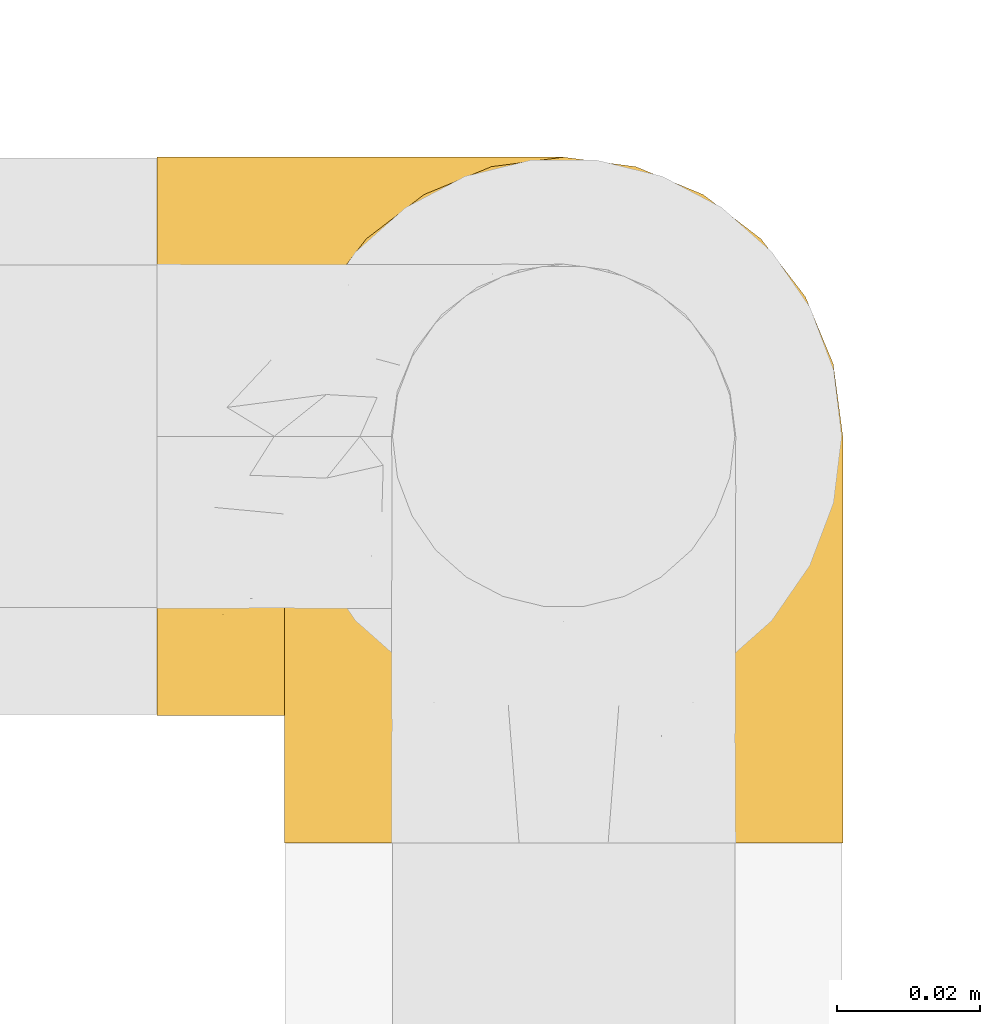
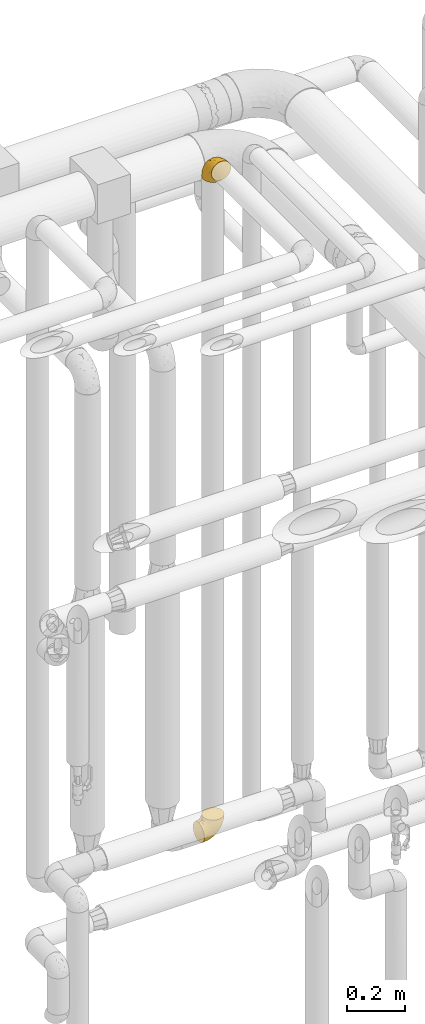
# One storey, part 501 of 827: 2 coverings.
"""IFC2X3 building model written with IfcOpenShell, lengths in millimetres."""

from ifc_helpers import new_model, entity, si_unit, converted_unit, derived_unit, direction, frame, origin, place, context, subcontext, project, spatial, faceted_brep, element, save


model = new_model("IFC2X3")

# Units and contexts
model_context = context("Model", 3, precision=0.01, world=origin(), true_north=direction((6.12303176911189e-17, 1.0)))
body_context = subcontext(model_context, "Body", "Model", "MODEL_VIEW")
ifc_project = project(units=[si_unit("LENGTHUNIT", "METRE", prefix="MILLI"), si_unit("AREAUNIT", "SQUARE_METRE"), si_unit("VOLUMEUNIT", "CUBIC_METRE"), converted_unit("PLANEANGLEUNIT", "DEGREE", entity("IfcRatioMeasure", 0.0174532925199433), si_unit("PLANEANGLEUNIT", "RADIAN"), dimensions=[0, 0, 0, 0, 0, 0, 0]), si_unit("MASSUNIT", "GRAM", prefix="KILO"), derived_unit("MASSDENSITYUNIT", [(si_unit("MASSUNIT", "GRAM", prefix="KILO"), 1), (si_unit("LENGTHUNIT", "METRE"), -3)]), derived_unit("MOMENTOFINERTIAUNIT", [(si_unit("LENGTHUNIT", "METRE"), 4)]), si_unit("TIMEUNIT", "SECOND"), si_unit("FREQUENCYUNIT", "HERTZ"), si_unit("THERMODYNAMICTEMPERATUREUNIT", "DEGREE_CELSIUS"), derived_unit("THERMALTRANSMITTANCEUNIT", [(si_unit("MASSUNIT", "GRAM", prefix="KILO"), 1), (si_unit("THERMODYNAMICTEMPERATUREUNIT", "KELVIN"), -1), (si_unit("TIMEUNIT", "SECOND"), -3)]), derived_unit("VOLUMETRICFLOWRATEUNIT", [(si_unit("LENGTHUNIT", "METRE"), 3), (si_unit("TIMEUNIT", "SECOND"), -1)]), derived_unit("MASSFLOWRATEUNIT", [(si_unit("MASSUNIT", "GRAM", prefix="KILO"), 1), (si_unit("TIMEUNIT", "SECOND"), -1)]), derived_unit("ROTATIONALFREQUENCYUNIT", [(si_unit("TIMEUNIT", "SECOND"), -1)]), si_unit("ELECTRICCURRENTUNIT", "AMPERE"), si_unit("ELECTRICVOLTAGEUNIT", "VOLT"), si_unit("POWERUNIT", "WATT"), si_unit("FORCEUNIT", "NEWTON", prefix="KILO"), si_unit("ILLUMINANCEUNIT", "LUX"), si_unit("LUMINOUSFLUXUNIT", "LUMEN"), si_unit("LUMINOUSINTENSITYUNIT", "CANDELA"), derived_unit("USERDEFINED", [(si_unit("MASSUNIT", "GRAM", prefix="KILO"), -1), (si_unit("LENGTHUNIT", "METRE"), -2), (si_unit("TIMEUNIT", "SECOND"), 3), (si_unit("LUMINOUSFLUXUNIT", "LUMEN"), 1)]), derived_unit("LINEARVELOCITYUNIT", [(si_unit("LENGTHUNIT", "METRE"), 1), (si_unit("TIMEUNIT", "SECOND"), -1)]), si_unit("PRESSUREUNIT", "PASCAL"), derived_unit("USERDEFINED", [(si_unit("LENGTHUNIT", "METRE"), -2), (si_unit("MASSUNIT", "GRAM", prefix="KILO"), 1), (si_unit("TIMEUNIT", "SECOND"), -2)]), derived_unit("LINEARFORCEUNIT", [(si_unit("MASSUNIT", "GRAM", prefix="KILO"), 1), (si_unit("LENGTHUNIT", "METRE"), 1), (si_unit("TIMEUNIT", "SECOND"), -2), (si_unit("LENGTHUNIT", "METRE"), -1)]), derived_unit("PLANARFORCEUNIT", [(si_unit("MASSUNIT", "GRAM", prefix="KILO"), 1), (si_unit("LENGTHUNIT", "METRE"), 1), (si_unit("TIMEUNIT", "SECOND"), -2), (si_unit("LENGTHUNIT", "METRE"), -2)])], contexts=[model_context])

# Site, building, storey
site_placement = place(None, origin())
site = spatial("IfcSite", under=ifc_project, at=site_placement, CompositionType="ELEMENT")
building_placement = place(site_placement, origin())
building = spatial("IfcBuilding", under=site, at=building_placement, CompositionType="ELEMENT")
storey_placement = place(building_placement, frame((0.0, 0.0, 28200.0)))
storey = spatial("IfcBuildingStorey", under=building, at=storey_placement, Name="08", CompositionType="ELEMENT", Elevation=28200.0)

# Coverings
covering_1_placement = place(storey_placement, frame((59757.39, 17441.4, 3141.4)))
element("IfcCovering", 1, at=covering_1_placement, inside=storey, Name=":ADSK_", ObjectType=":ADSK_", PredefinedType="INSULATION", context=body_context, shape_type="Brep", body=[
    faceted_brep([(79.9, 1.6, 58.6), (78.91, 1.6, 67.31), (76.02, 1.6, 75.59), (71.35, 1.6, 83.01), (65.15, 1.6, 89.21), (57.73, 1.6, 93.87), (49.45, 1.6, 96.76), (40.75, 1.6, 97.75), (32.03, 1.6, 96.76), (23.75, 1.6, 93.87), (16.33, 1.6, 89.2), (10.13, 1.6, 83.0), (5.47, 1.6, 75.58), (2.58, 1.6, 67.3), (1.6, 1.6, 58.6), (1.96, 1.6, 55.4), (2.58, 1.6, 49.88), (4.03, 1.6, 45.74), (5.48, 1.6, 41.6), (10.14, 1.6, 34.18), (16.34, 1.6, 27.98), (23.76, 1.6, 23.32), (32.04, 1.6, 20.43), (40.75, 1.6, 19.45), (49.46, 1.6, 20.43), (57.74, 1.6, 23.33), (65.16, 1.6, 27.99), (71.36, 1.6, 34.19), (76.02, 1.6, 41.61), (78.91, 1.6, 49.89), (79.54, 1.6, 55.4), (13.06, 30.91, 1.6), (6.84, 39.02, 1.6), (2.93, 48.46, 1.6), (2.44, 52.18, 1.6), (2.02, 55.39, 1.6), (1.6, 58.6, 1.6), (2.93, 68.73, 1.6), (6.84, 78.17, 1.6), (13.06, 86.28, 1.6), (21.17, 92.5, 1.6), (30.61, 96.41, 1.6), (40.75, 97.75, 1.6), (50.88, 96.41, 1.6), (60.32, 92.5, 1.6), (68.43, 86.28, 1.6), (74.65, 78.17, 1.6), (78.56, 68.73, 1.6), (79.9, 58.6, 1.6), (79.05, 52.18, 1.6), (78.56, 48.46, 1.6), (74.65, 39.02, 1.6), (68.43, 30.91, 1.6), (60.32, 24.69, 1.6), (50.88, 20.78, 1.6), (40.75, 19.45, 1.6), (30.61, 20.78, 1.6), (21.17, 24.69, 1.6), (40.75, 68.75, 68.75), (40.75, 58.11, 79.38), (53.99, 67.95, 67.95), (40.75, 79.38, 58.11), (40.75, 93.04, 31.31), (47.49, 94.13, 25.48), (40.75, 94.7, 20.85), (51.52, 83.92, 48.28), (61.86, 83.74, 38.29), (54.43, 92.46, 24.38), (63.37, 88.89, 18.7), (79.25, 18.55, 63.4), (77.04, 59.47, 43.9), (75.79, 73.43, 21.15), (72.61, 70.77, 41.26), (78.93, 64.34, 20.94), (70.12, 81.19, 24.69), (66.7, 24.77, 84.73), (72.7, 18.96, 79.29), (70.21, 39.69, 75.09), (78.8, 39.98, 55.53), (79.9, 23.41, 54.26), (79.9, 28.03, 51.17), (79.9, 32.65, 48.08), (79.9, 37.28, 44.99), (79.9, 41.9, 41.9), (74.44, 52.71, 59.1), (52.47, 24.51, 93.12), (79.33, 53.67, 38.11), (79.9, 44.99, 37.28), (79.9, 48.08, 32.65), (79.9, 51.17, 28.03), (79.9, 54.26, 23.41), (48.94, 45.31, 86.26), (58.78, 41.19, 84.36), (60.43, 18.54, 90.84), (40.75, 20.85, 94.7), (62.02, 67.52, 62.67), (57.53, 55.82, 76.37), (79.9, 5.17, 57.88), (79.9, 8.74, 57.17), (79.9, 15.88, 55.75), (64.12, 52.18, 74.1), (75.76, 35.23, 68.09), (76.65, 17.8, 72.38), (68.92, 60.91, 61.34), (66.73, 73.89, 48.69), (40.75, 86.21, 44.71), (40.75, 31.31, 93.04), (79.9, 55.75, 15.88), (79.9, 56.46, 12.31), (79.9, 57.17, 8.74), (40.75, 44.71, 86.21), (63.86, 26.29, 7.55), (69.15, 29.74, 12.14), (78.65, 47.68, 11.84), (72.98, 35.46, 9.55), (76.47, 41.52, 10.89), (76.82, 40.21, 17.57), (79.05, 47.09, 19.53), (79.09, 44.48, 25.5), (51.28, 19.96, 7.5), (51.03, 17.27, 12.73), (40.75, 14.22, 14.22), (40.75, 16.71, 8.19), (49.93, 10.14, 18.5), (58.53, 13.28, 20.38), (69.86, 17.56, 27.96), (65.19, 17.71, 22.53), (70.75, 23.15, 25.05), (79.25, 8.48, 51.05), (79.11, 13.45, 49.37), (57.89, 22.84, 6.49), (55.93, 7.02, 21.79), (78.06, 29.23, 37.29), (75.39, 29.51, 28.49), (78.16, 33.67, 33.82), (66.62, 23.34, 18.63), (73.14, 30.5, 21.37), (71.07, 7.97, 33.2), (78.32, 22.97, 42.33), (73.93, 16.17, 34.77), (77.25, 13.36, 42.81), (79.26, 19.39, 48.27), (60.3, 18.33, 17.49), (40.75, 8.19, 16.71), (65.72, 10.82, 26.81), (74.5, 23.48, 31.65), (60.62, 21.93, 12.9), (73.96, 34.48, 16.9), (77.3, 38.65, 23.37), (77.83, 36.64, 28.95), (23.6, 22.84, 6.49), (17.57, 25.49, 10.35), (1.6, 5.17, 57.88), (1.6, 8.74, 57.17), (1.6, 15.88, 55.75), (31.57, 10.14, 18.5), (22.97, 13.28, 20.37), (25.57, 7.02, 21.79), (15.78, 10.82, 26.8), (1.6, 55.75, 15.88), (1.6, 57.17, 8.74), (1.6, 57.88, 5.17), (12.34, 29.74, 12.14), (7.57, 34.5, 16.74), (8.85, 34.84, 10.0), (2.63, 46.53, 18.6), (4.67, 40.21, 17.57), (2.36, 44.84, 25.3), (1.6, 54.26, 23.41), (2.84, 47.68, 11.84), (2.24, 19.39, 48.27), (1.6, 28.03, 51.17), (3.18, 22.96, 42.31), (10.74, 23.16, 25.03), (15.18, 22.9, 18.73), (16.42, 17.91, 22.25), (30.21, 19.96, 7.5), (9.98, 28.63, 20.15), (30.46, 17.27, 12.73), (10.43, 7.97, 33.19), (12.05, 17.45, 27.5), (4.24, 13.36, 42.79), (7.56, 16.17, 34.75), (3.43, 29.23, 37.29), (2.38, 13.44, 49.36), (1.6, 23.41, 54.26), (3.66, 36.64, 28.95), (4.45, 38.11, 22.98), (6.98, 23.51, 31.63), (6.12, 29.52, 28.42), (5.38, 40.9, 10.01), (21.58, 18.21, 17.3), (3.35, 33.63, 33.78), (1.6, 37.28, 44.99), (20.87, 21.93, 12.9), (1.6, 44.99, 37.28), (1.6, 41.9, 41.9), (1.6, 51.17, 28.03), (1.6, 48.08, 32.65), (1.6, 32.65, 48.08), (2.16, 53.67, 38.11), (11.37, 81.19, 24.7), (5.7, 73.43, 21.15), (8.88, 70.76, 41.27), (12.57, 60.91, 61.33), (7.04, 52.7, 59.09), (11.27, 39.68, 75.08), (17.36, 52.18, 74.09), (2.69, 39.98, 55.53), (2.56, 64.34, 20.94), (34.0, 94.13, 25.48), (27.06, 92.46, 24.38), (4.45, 59.46, 43.89), (5.73, 35.22, 68.08), (18.12, 88.89, 18.7), (19.63, 83.74, 38.29), (27.49, 67.95, 67.95), (19.46, 67.52, 62.66), (2.24, 18.55, 63.4), (29.01, 24.51, 93.12), (14.78, 24.77, 84.73), (32.55, 45.32, 86.25), (8.78, 18.96, 79.28), (29.98, 83.92, 48.28), (23.95, 55.82, 76.37), (22.7, 41.19, 84.35), (21.05, 18.54, 90.83), (14.75, 73.87, 48.7), (4.84, 17.8, 72.37)], [[[0, 1, 2, 3, 4, 5, 6, 7, 8, 9, 10, 11, 12, 13, 14, 15, 16, 17, 18, 19, 20, 21, 22, 23, 24, 25, 26, 27, 28, 29, 30]], [[31, 32, 33, 34, 35, 36, 37, 38, 39, 40, 41, 42, 43, 44, 45, 46, 47, 48, 49, 50, 51, 52, 53, 54, 55, 56, 57]], [[58, 59, 60, 61]], [[62, 63, 64]], [[65, 66, 67]], [[67, 66, 68]], [[69, 1, 0]], [[70, 71, 72]], [[44, 43, 67]], [[47, 71, 73]], [[45, 74, 46]], [[68, 45, 44]], [[75, 76, 77]], [[76, 3, 2]], [[78, 79, 80, 81, 82, 83]], [[48, 47, 73]], [[70, 72, 84]], [[5, 85, 6]], [[86, 83, 87, 88, 89, 90]], [[91, 85, 92]], [[76, 75, 3]], [[71, 46, 74]], [[85, 5, 93]], [[45, 68, 74]], [[5, 4, 93]], [[85, 94, 6]], [[86, 78, 83]], [[60, 95, 65]], [[96, 95, 60]], [[75, 4, 3]], [[69, 0, 97, 98, 99, 79]], [[75, 77, 100]], [[43, 64, 63]], [[101, 102, 69]], [[101, 76, 102]], [[46, 71, 47]], [[95, 103, 104]], [[92, 85, 93]], [[63, 105, 65]], [[92, 75, 100]], [[91, 106, 85]], [[84, 78, 70]], [[67, 68, 44]], [[65, 67, 63]], [[65, 61, 60]], [[4, 75, 93]], [[92, 93, 75]], [[102, 76, 2]], [[77, 76, 101]], [[84, 77, 101]], [[77, 103, 100]], [[72, 71, 74]], [[70, 86, 73]], [[104, 74, 66]], [[84, 72, 103]], [[70, 73, 71]], [[73, 90, 107, 108, 109, 48]], [[79, 78, 69]], [[101, 69, 78]], [[91, 92, 96]], [[91, 59, 110, 106]], [[2, 1, 102]], [[69, 102, 1]], [[94, 85, 106]], [[94, 7, 6]], [[74, 68, 66]], [[43, 42, 64]], [[43, 63, 67]], [[73, 86, 90]], [[78, 86, 70]], [[95, 100, 103]], [[96, 92, 100]], [[104, 103, 72]], [[65, 95, 66]], [[74, 104, 72]], [[66, 95, 104]], [[95, 96, 100]], [[91, 96, 60]], [[77, 84, 103]], [[78, 84, 101]], [[60, 59, 91]], [[105, 63, 62]], [[105, 61, 65]], [[111, 52, 112]], [[107, 90, 113]], [[114, 115, 116]], [[50, 107, 113]], [[117, 118, 116]], [[54, 119, 55]], [[97, 0, 30, 29, 98]], [[113, 115, 51]], [[120, 121, 122]], [[123, 120, 124]], [[125, 126, 127]], [[128, 28, 129]], [[130, 54, 53]], [[25, 24, 131]], [[132, 133, 134]], [[135, 112, 136]], [[137, 27, 26]], [[121, 120, 123]], [[138, 139, 132]], [[129, 140, 141]], [[135, 126, 142]], [[27, 140, 28]], [[27, 137, 140]], [[49, 48, 109, 108, 107, 50]], [[23, 143, 121, 123]], [[25, 131, 144]], [[26, 25, 144]], [[128, 98, 29]], [[125, 127, 145]], [[146, 130, 111]], [[137, 144, 139]], [[139, 138, 140]], [[116, 147, 114]], [[123, 124, 131]], [[116, 118, 148]], [[134, 83, 82]], [[129, 79, 99]], [[54, 130, 119]], [[141, 79, 129]], [[122, 55, 119]], [[120, 146, 142]], [[117, 113, 90]], [[50, 113, 51]], [[127, 133, 145]], [[147, 136, 112]], [[136, 133, 127]], [[24, 23, 123]], [[118, 117, 89]], [[149, 87, 134]], [[144, 131, 124]], [[24, 123, 131]], [[128, 129, 99]], [[28, 140, 129]], [[144, 137, 26]], [[140, 137, 139]], [[81, 138, 132]], [[138, 80, 141]], [[89, 88, 87, 118]], [[115, 117, 116]], [[140, 138, 141]], [[148, 118, 149]], [[136, 148, 149]], [[147, 116, 148]], [[133, 136, 149]], [[127, 126, 135]], [[136, 147, 148]], [[114, 112, 52]], [[112, 114, 147]], [[51, 114, 52]], [[51, 115, 114]], [[117, 115, 113]], [[117, 90, 89]], [[134, 133, 149]], [[145, 133, 132]], [[132, 139, 145]], [[125, 139, 144]], [[139, 125, 145]], [[126, 144, 124]], [[144, 126, 125]], [[142, 126, 124]], [[120, 142, 124]], [[142, 146, 135]], [[112, 135, 146]], [[136, 127, 135]], [[118, 87, 149]], [[82, 81, 132]], [[111, 130, 53]], [[119, 146, 120]], [[146, 119, 130]], [[122, 119, 120]], [[52, 111, 53]], [[146, 111, 112]], [[134, 82, 132]], [[83, 134, 87]], [[98, 128, 99]], [[80, 138, 81]], [[80, 79, 141]], [[28, 128, 29]], [[150, 151, 57]], [[15, 14, 152, 153, 154, 16]], [[121, 143, 23, 155]], [[150, 57, 56]], [[156, 157, 158]], [[35, 34, 33, 159, 160, 161, 36]], [[162, 31, 57]], [[163, 164, 162]], [[165, 166, 167]], [[155, 23, 22]], [[168, 159, 169]], [[170, 171, 172]], [[173, 174, 175]], [[55, 122, 176]], [[177, 174, 173]], [[22, 157, 155]], [[178, 121, 155]], [[169, 33, 32]], [[20, 19, 179]], [[21, 20, 158]], [[158, 180, 175]], [[181, 182, 179]], [[172, 183, 182]], [[122, 121, 178]], [[181, 19, 18]], [[184, 185, 170]], [[17, 154, 184]], [[186, 187, 177]], [[187, 186, 167]], [[179, 158, 20]], [[21, 157, 22]], [[175, 180, 173]], [[188, 189, 173]], [[164, 166, 190]], [[185, 184, 154]], [[181, 172, 182]], [[156, 191, 178]], [[192, 183, 193]], [[178, 176, 122]], [[194, 150, 176]], [[33, 169, 159]], [[190, 169, 32]], [[189, 192, 186]], [[180, 188, 173]], [[167, 166, 187]], [[166, 164, 163]], [[195, 192, 196]], [[158, 157, 21]], [[155, 157, 156]], [[178, 155, 156]], [[181, 18, 184]], [[17, 16, 154]], [[181, 179, 19]], [[158, 179, 182]], [[170, 181, 184]], [[192, 195, 186]], [[31, 190, 32]], [[165, 190, 166]], [[190, 31, 164]], [[31, 162, 164]], [[177, 163, 162]], [[187, 166, 163]], [[151, 174, 177]], [[177, 173, 189]], [[177, 187, 163]], [[195, 167, 186]], [[165, 197, 168]], [[165, 168, 169]], [[167, 197, 165]], [[190, 165, 169]], [[167, 195, 198, 197]], [[151, 177, 162]], [[175, 191, 156]], [[191, 174, 194]], [[158, 175, 156]], [[174, 191, 175]], [[178, 191, 194]], [[158, 182, 180]], [[188, 182, 183]], [[182, 188, 180]], [[183, 192, 189]], [[183, 189, 188]], [[177, 189, 186]], [[183, 199, 193]], [[176, 150, 56]], [[151, 150, 194]], [[176, 56, 55]], [[194, 176, 178]], [[174, 151, 194]], [[57, 151, 162]], [[199, 183, 172]], [[196, 192, 193]], [[171, 199, 172]], [[172, 181, 170]], [[170, 185, 171]], [[184, 18, 17]], [[200, 168, 197, 198, 195, 196]], [[201, 202, 203]], [[204, 203, 205]], [[204, 206, 207]], [[208, 196, 193, 199, 171, 185]], [[209, 36, 161, 160, 159, 168]], [[202, 38, 37]], [[201, 38, 202]], [[210, 41, 211]], [[200, 208, 212]], [[205, 208, 213]], [[214, 211, 40]], [[40, 211, 41]], [[214, 201, 215]], [[58, 61, 216, 59]], [[201, 39, 38]], [[207, 217, 204]], [[213, 208, 218]], [[218, 185, 154, 153, 152, 14]], [[14, 13, 218]], [[9, 8, 219]], [[10, 220, 11]], [[221, 106, 110, 59]], [[219, 8, 94]], [[220, 222, 11]], [[223, 211, 215]], [[221, 216, 224]], [[225, 219, 221]], [[10, 9, 226]], [[213, 222, 206]], [[226, 9, 219]], [[106, 219, 94]], [[212, 202, 209]], [[201, 203, 227]], [[226, 225, 220]], [[207, 206, 220]], [[214, 40, 39]], [[11, 222, 12]], [[12, 222, 228]], [[41, 210, 64]], [[223, 105, 210]], [[223, 215, 217]], [[105, 62, 210]], [[206, 222, 220]], [[228, 222, 213]], [[207, 220, 225]], [[205, 206, 204]], [[225, 226, 219]], [[220, 10, 226]], [[209, 202, 37]], [[203, 202, 212]], [[205, 203, 212]], [[204, 217, 227]], [[36, 209, 37]], [[209, 168, 200]], [[218, 13, 228]], [[208, 185, 218]], [[106, 221, 219]], [[221, 59, 216]], [[218, 228, 213]], [[13, 12, 228]], [[8, 7, 94]], [[201, 214, 39]], [[211, 214, 215]], [[64, 210, 62]], [[64, 42, 41]], [[223, 210, 211]], [[208, 200, 196]], [[209, 200, 212]], [[225, 224, 207]], [[207, 224, 217]], [[223, 217, 216]], [[204, 227, 203]], [[217, 215, 227]], [[201, 227, 215]], [[221, 224, 225]], [[217, 224, 216]], [[208, 205, 212]], [[206, 205, 213]], [[216, 61, 223]], [[223, 61, 105]]]),
])
covering_2_placement = place(storey_placement, frame((59739.54, 17459.25, 359.25)))
element("IfcCovering", 2, at=covering_2_placement, inside=storey, Name=":ADSK_", ObjectType=":ADSK_", PredefinedType="INSULATION", context=body_context, shape_type="Brep", body=[
    faceted_brep([(1.6, 79.9, 40.75), (1.6, 78.91, 32.03), (1.6, 76.02, 23.75), (1.6, 71.35, 16.33), (1.6, 65.15, 10.13), (1.6, 57.73, 5.47), (1.6, 49.45, 2.58), (1.6, 40.75, 1.6), (1.6, 32.03, 2.58), (1.6, 23.75, 5.48), (1.6, 16.33, 10.14), (1.6, 10.13, 16.34), (1.6, 5.47, 23.76), (1.6, 2.58, 32.04), (1.6, 1.6, 40.75), (1.6, 1.96, 43.94), (1.6, 2.58, 49.46), (1.6, 4.03, 53.6), (1.6, 5.48, 57.74), (1.6, 10.14, 65.16), (1.6, 16.34, 71.36), (1.6, 23.76, 76.02), (1.6, 32.04, 78.91), (1.6, 40.75, 79.9), (1.6, 49.46, 78.91), (1.6, 57.74, 76.02), (1.6, 65.16, 71.35), (1.6, 71.36, 65.15), (1.6, 76.02, 57.73), (1.6, 78.91, 49.45), (1.6, 79.54, 43.94), (30.91, 13.06, 97.75), (39.02, 6.84, 97.75), (48.46, 2.93, 97.75), (52.18, 2.44, 97.75), (55.39, 2.02, 97.75), (58.6, 1.6, 97.75), (68.73, 2.93, 97.75), (78.17, 6.84, 97.75), (86.28, 13.06, 97.75), (92.5, 21.17, 97.75), (96.41, 30.61, 97.75), (97.75, 40.75, 97.75), (96.41, 50.88, 97.75), (92.5, 60.32, 97.75), (86.28, 68.43, 97.75), (78.17, 74.65, 97.75), (68.73, 78.56, 97.75), (58.6, 79.9, 97.75), (52.18, 79.05, 97.75), (48.46, 78.56, 97.75), (39.02, 74.65, 97.75), (30.91, 68.43, 97.75), (24.69, 60.32, 97.75), (20.78, 50.88, 97.75), (19.45, 40.75, 97.75), (20.78, 30.61, 97.75), (24.69, 21.17, 97.75), (68.75, 40.75, 30.59), (58.11, 40.75, 19.96), (67.95, 53.99, 31.39), (79.38, 40.75, 41.23), (93.04, 40.75, 68.03), (94.13, 47.49, 73.86), (94.7, 40.75, 78.49), (83.92, 51.52, 51.06), (83.74, 61.86, 61.05), (92.46, 54.43, 74.96), (88.89, 63.37, 80.64), (18.55, 79.25, 35.94), (59.47, 77.04, 55.44), (73.43, 75.79, 78.19), (70.77, 72.61, 58.08), (64.34, 78.93, 78.4), (81.19, 70.12, 74.65), (24.77, 66.7, 14.61), (18.96, 72.7, 20.05), (39.69, 70.21, 24.25), (39.98, 78.8, 43.81), (23.41, 79.9, 45.08), (28.03, 79.9, 48.17), (32.65, 79.9, 51.26), (37.28, 79.9, 54.35), (41.9, 79.9, 57.44), (52.71, 74.44, 40.25), (24.51, 52.47, 6.22), (53.67, 79.33, 61.23), (44.99, 79.9, 62.06), (48.08, 79.9, 66.69), (51.17, 79.9, 71.31), (54.26, 79.9, 75.93), (45.31, 48.94, 13.08), (41.19, 58.78, 14.98), (18.54, 60.43, 8.5), (20.85, 40.75, 4.64), (67.52, 62.02, 36.67), (55.82, 57.53, 22.97), (5.17, 79.9, 41.46), (8.74, 79.9, 42.17), (15.88, 79.9, 43.59), (52.18, 64.12, 25.24), (35.23, 75.76, 31.25), (17.8, 76.65, 26.96), (60.91, 68.92, 38.0), (73.89, 66.73, 50.65), (86.21, 40.75, 54.63), (31.31, 40.75, 6.3), (55.75, 79.9, 83.46), (56.46, 79.9, 87.03), (57.17, 79.9, 90.6), (44.71, 40.75, 13.13), (26.29, 63.86, 91.79), (29.74, 69.15, 87.2), (47.68, 78.65, 87.5), (35.46, 72.98, 89.79), (41.52, 76.47, 88.45), (40.21, 76.82, 81.77), (47.09, 79.05, 79.81), (44.48, 79.09, 73.84), (19.96, 51.28, 91.84), (17.27, 51.03, 86.62), (14.22, 40.75, 85.12), (16.71, 40.75, 91.15), (10.14, 49.93, 80.84), (13.28, 58.53, 78.96), (17.56, 69.86, 71.38), (17.71, 65.19, 76.81), (23.15, 70.75, 74.29), (8.48, 79.25, 48.29), (13.45, 79.11, 49.97), (22.84, 57.89, 92.85), (7.02, 55.93, 77.55), (29.23, 78.06, 62.05), (29.51, 75.39, 70.85), (33.67, 78.16, 65.52), (23.34, 66.62, 80.71), (30.5, 73.14, 77.97), (7.97, 71.07, 66.14), (22.97, 78.32, 57.01), (16.17, 73.93, 64.57), (13.36, 77.25, 56.53), (19.39, 79.26, 51.07), (18.33, 60.3, 81.85), (8.19, 40.75, 82.63), (10.82, 65.72, 72.53), (23.48, 74.5, 67.69), (21.93, 60.62, 86.44), (34.48, 73.96, 82.44), (38.65, 77.3, 75.97), (36.64, 77.83, 70.39), (22.84, 23.6, 92.85), (25.49, 17.57, 88.99), (5.17, 1.6, 41.46), (8.74, 1.6, 42.17), (15.88, 1.6, 43.59), (10.14, 31.57, 80.84), (13.28, 22.97, 78.97), (7.02, 25.57, 77.55), (10.82, 15.78, 72.54), (55.75, 1.6, 83.46), (57.17, 1.6, 90.6), (57.88, 1.6, 94.17), (29.74, 12.34, 87.2), (34.5, 7.57, 82.6), (34.84, 8.85, 89.34), (46.53, 2.63, 80.74), (40.21, 4.67, 81.77), (44.84, 2.36, 74.04), (54.26, 1.6, 75.93), (47.68, 2.84, 87.5), (19.39, 2.24, 51.07), (28.03, 1.6, 48.17), (22.96, 3.18, 57.03), (23.16, 10.74, 74.31), (22.9, 15.18, 80.61), (17.91, 16.42, 77.09), (19.96, 30.21, 91.84), (28.63, 9.98, 79.19), (17.27, 30.46, 86.62), (7.97, 10.43, 66.15), (17.45, 12.05, 71.84), (13.36, 4.24, 56.55), (16.17, 7.56, 64.59), (29.23, 3.43, 62.05), (13.44, 2.38, 49.99), (23.41, 1.6, 45.08), (36.64, 3.66, 70.39), (38.11, 4.45, 76.36), (23.51, 6.98, 67.71), (29.52, 6.12, 70.92), (40.9, 5.38, 89.33), (18.21, 21.58, 82.04), (32.65, 1.6, 51.26), (21.93, 20.87, 86.44), (33.63, 3.35, 65.56), (44.99, 1.6, 62.06), (41.9, 1.6, 57.44), (37.28, 1.6, 54.35), (51.17, 1.6, 71.31), (48.08, 1.6, 66.69), (53.67, 2.16, 61.23), (81.19, 11.37, 74.65), (73.43, 5.7, 78.19), (70.76, 8.88, 58.07), (60.91, 12.57, 38.01), (52.7, 7.04, 40.25), (39.68, 11.27, 24.26), (52.18, 17.36, 25.25), (39.98, 2.69, 43.81), (64.34, 2.56, 78.4), (94.13, 34.0, 73.86), (92.46, 27.06, 74.96), (59.46, 4.45, 55.45), (35.22, 5.73, 31.26), (88.89, 18.12, 80.64), (83.74, 19.63, 61.05), (67.95, 27.49, 31.39), (67.52, 19.46, 36.69), (18.55, 2.24, 35.95), (24.51, 29.01, 6.22), (24.77, 14.78, 14.62), (45.32, 32.55, 13.09), (18.96, 8.78, 20.06), (83.92, 29.98, 51.06), (55.82, 23.95, 22.97), (41.19, 22.7, 14.99), (18.54, 21.05, 8.51), (73.87, 14.75, 50.64), (17.8, 4.84, 26.97)], [[[0, 1, 2, 3, 4, 5, 6, 7, 8, 9, 10, 11, 12, 13, 14, 15, 16, 17, 18, 19, 20, 21, 22, 23, 24, 25, 26, 27, 28, 29, 30]], [[31, 32, 33, 34, 35, 36, 37, 38, 39, 40, 41, 42, 43, 44, 45, 46, 47, 48, 49, 50, 51, 52, 53, 54, 55, 56, 57]], [[58, 59, 60, 61]], [[62, 63, 64]], [[65, 66, 67]], [[67, 66, 68]], [[69, 1, 0]], [[70, 71, 72]], [[44, 43, 67]], [[47, 71, 73]], [[45, 74, 46]], [[68, 45, 44]], [[75, 76, 77]], [[76, 3, 2]], [[78, 79, 80, 81, 82, 83]], [[48, 47, 73]], [[70, 72, 84]], [[5, 85, 6]], [[86, 83, 87, 88, 89, 90]], [[91, 85, 92]], [[76, 75, 3]], [[71, 46, 74]], [[85, 5, 93]], [[45, 68, 74]], [[5, 4, 93]], [[85, 94, 6]], [[86, 78, 83]], [[60, 95, 65]], [[96, 95, 60]], [[75, 4, 3]], [[69, 0, 97, 98, 99, 79]], [[75, 77, 100]], [[43, 64, 63]], [[101, 102, 69]], [[101, 76, 102]], [[46, 71, 47]], [[95, 103, 104]], [[92, 85, 93]], [[63, 105, 65]], [[92, 75, 100]], [[91, 106, 85]], [[84, 78, 70]], [[67, 68, 44]], [[65, 67, 63]], [[65, 61, 60]], [[4, 75, 93]], [[92, 93, 75]], [[102, 76, 2]], [[77, 76, 101]], [[84, 77, 101]], [[77, 103, 100]], [[72, 71, 74]], [[70, 86, 73]], [[104, 74, 66]], [[84, 72, 103]], [[70, 73, 71]], [[73, 90, 107, 108, 109, 48]], [[79, 78, 69]], [[101, 69, 78]], [[91, 92, 96]], [[91, 59, 110, 106]], [[2, 1, 102]], [[69, 102, 1]], [[94, 85, 106]], [[94, 7, 6]], [[74, 68, 66]], [[43, 42, 64]], [[43, 63, 67]], [[73, 86, 90]], [[78, 86, 70]], [[95, 100, 103]], [[96, 92, 100]], [[104, 103, 72]], [[65, 95, 66]], [[74, 104, 72]], [[66, 95, 104]], [[95, 96, 100]], [[91, 96, 60]], [[77, 84, 103]], [[78, 84, 101]], [[60, 59, 91]], [[105, 63, 62]], [[105, 61, 65]], [[111, 52, 112]], [[107, 90, 113]], [[114, 115, 116]], [[50, 107, 113]], [[117, 118, 116]], [[54, 119, 55]], [[97, 0, 30, 29, 98]], [[113, 115, 51]], [[120, 121, 122]], [[123, 120, 124]], [[125, 126, 127]], [[128, 28, 129]], [[130, 54, 53]], [[25, 24, 131]], [[132, 133, 134]], [[135, 112, 136]], [[137, 27, 26]], [[121, 120, 123]], [[138, 139, 132]], [[129, 140, 141]], [[135, 126, 142]], [[27, 140, 28]], [[27, 137, 140]], [[49, 48, 109, 108, 107, 50]], [[23, 143, 121, 123]], [[25, 131, 144]], [[26, 25, 144]], [[128, 98, 29]], [[125, 127, 145]], [[146, 130, 111]], [[137, 144, 139]], [[139, 138, 140]], [[116, 147, 114]], [[123, 124, 131]], [[116, 118, 148]], [[134, 83, 82]], [[129, 79, 99]], [[54, 130, 119]], [[141, 79, 129]], [[122, 55, 119]], [[120, 146, 142]], [[117, 113, 90]], [[50, 113, 51]], [[127, 133, 145]], [[147, 136, 112]], [[136, 133, 127]], [[24, 23, 123]], [[118, 117, 89]], [[149, 87, 134]], [[144, 131, 124]], [[24, 123, 131]], [[128, 129, 99]], [[28, 140, 129]], [[144, 137, 26]], [[140, 137, 139]], [[81, 138, 132]], [[138, 80, 141]], [[89, 88, 87, 118]], [[115, 117, 116]], [[140, 138, 141]], [[148, 118, 149]], [[136, 148, 149]], [[147, 116, 148]], [[133, 136, 149]], [[127, 126, 135]], [[136, 147, 148]], [[114, 112, 52]], [[112, 114, 147]], [[51, 114, 52]], [[51, 115, 114]], [[117, 115, 113]], [[117, 90, 89]], [[134, 133, 149]], [[145, 133, 132]], [[132, 139, 145]], [[125, 139, 144]], [[139, 125, 145]], [[126, 144, 124]], [[144, 126, 125]], [[142, 126, 124]], [[120, 142, 124]], [[142, 146, 135]], [[112, 135, 146]], [[136, 127, 135]], [[118, 87, 149]], [[82, 81, 132]], [[111, 130, 53]], [[119, 146, 120]], [[146, 119, 130]], [[122, 119, 120]], [[52, 111, 53]], [[146, 111, 112]], [[134, 82, 132]], [[83, 134, 87]], [[98, 128, 99]], [[80, 138, 81]], [[80, 79, 141]], [[28, 128, 29]], [[150, 151, 57]], [[15, 14, 152, 153, 154, 16]], [[121, 143, 23, 155]], [[150, 57, 56]], [[156, 157, 158]], [[35, 34, 33, 159, 160, 161, 36]], [[162, 31, 57]], [[163, 164, 162]], [[165, 166, 167]], [[155, 23, 22]], [[168, 159, 169]], [[170, 171, 172]], [[173, 174, 175]], [[55, 122, 176]], [[177, 174, 173]], [[22, 157, 155]], [[178, 121, 155]], [[169, 33, 32]], [[20, 19, 179]], [[21, 20, 158]], [[158, 180, 175]], [[181, 182, 179]], [[172, 183, 182]], [[122, 121, 178]], [[181, 19, 18]], [[184, 185, 170]], [[17, 154, 184]], [[186, 187, 177]], [[187, 186, 167]], [[179, 158, 20]], [[21, 157, 22]], [[175, 180, 173]], [[188, 189, 173]], [[164, 166, 190]], [[185, 184, 154]], [[181, 172, 182]], [[156, 191, 178]], [[192, 183, 172]], [[178, 176, 122]], [[193, 150, 176]], [[33, 169, 159]], [[190, 169, 32]], [[189, 194, 186]], [[180, 188, 173]], [[167, 166, 187]], [[166, 164, 163]], [[195, 194, 196]], [[158, 157, 21]], [[155, 157, 156]], [[178, 155, 156]], [[181, 18, 184]], [[17, 16, 154]], [[181, 179, 19]], [[158, 179, 182]], [[170, 181, 184]], [[196, 194, 197]], [[31, 190, 32]], [[165, 190, 166]], [[190, 31, 164]], [[31, 162, 164]], [[177, 163, 162]], [[187, 166, 163]], [[151, 174, 177]], [[177, 173, 189]], [[177, 187, 163]], [[195, 167, 186]], [[165, 198, 168]], [[165, 168, 169]], [[167, 198, 165]], [[190, 165, 169]], [[167, 195, 199, 198]], [[151, 177, 162]], [[175, 191, 156]], [[191, 174, 193]], [[158, 175, 156]], [[174, 191, 175]], [[178, 191, 193]], [[158, 182, 180]], [[188, 182, 183]], [[182, 188, 180]], [[183, 194, 189]], [[183, 189, 188]], [[177, 189, 186]], [[194, 183, 197]], [[176, 150, 56]], [[151, 150, 193]], [[176, 56, 55]], [[193, 176, 178]], [[174, 151, 193]], [[57, 151, 162]], [[183, 192, 197]], [[194, 195, 186]], [[171, 192, 172]], [[172, 181, 170]], [[170, 185, 171]], [[184, 18, 17]], [[200, 168, 198, 199, 195, 196]], [[201, 202, 203]], [[204, 203, 205]], [[204, 206, 207]], [[208, 196, 197, 192, 171, 185]], [[209, 36, 161, 160, 159, 168]], [[202, 38, 37]], [[201, 38, 202]], [[210, 41, 211]], [[200, 208, 212]], [[205, 208, 213]], [[214, 211, 40]], [[40, 211, 41]], [[214, 201, 215]], [[58, 61, 216, 59]], [[201, 39, 38]], [[207, 217, 204]], [[213, 208, 218]], [[218, 185, 154, 153, 152, 14]], [[14, 13, 218]], [[9, 8, 219]], [[10, 220, 11]], [[221, 106, 110, 59]], [[219, 8, 94]], [[220, 222, 11]], [[223, 211, 215]], [[221, 216, 224]], [[225, 219, 221]], [[10, 9, 226]], [[213, 222, 206]], [[226, 9, 219]], [[106, 219, 94]], [[212, 202, 209]], [[201, 203, 227]], [[226, 225, 220]], [[207, 206, 220]], [[214, 40, 39]], [[11, 222, 12]], [[12, 222, 228]], [[41, 210, 64]], [[223, 105, 210]], [[223, 215, 217]], [[105, 62, 210]], [[206, 222, 220]], [[228, 222, 213]], [[207, 220, 225]], [[205, 206, 204]], [[225, 226, 219]], [[220, 10, 226]], [[209, 202, 37]], [[203, 202, 212]], [[205, 203, 212]], [[204, 217, 227]], [[36, 209, 37]], [[209, 168, 200]], [[218, 13, 228]], [[208, 185, 218]], [[106, 221, 219]], [[221, 59, 216]], [[218, 228, 213]], [[13, 12, 228]], [[8, 7, 94]], [[201, 214, 39]], [[211, 214, 215]], [[64, 210, 62]], [[64, 42, 41]], [[223, 210, 211]], [[208, 200, 196]], [[209, 200, 212]], [[225, 224, 207]], [[207, 224, 217]], [[223, 217, 216]], [[204, 227, 203]], [[217, 215, 227]], [[201, 227, 215]], [[221, 224, 225]], [[217, 224, 216]], [[208, 205, 212]], [[206, 205, 213]], [[216, 61, 223]], [[223, 61, 105]]]),
])

save(model, "model.ifc")
